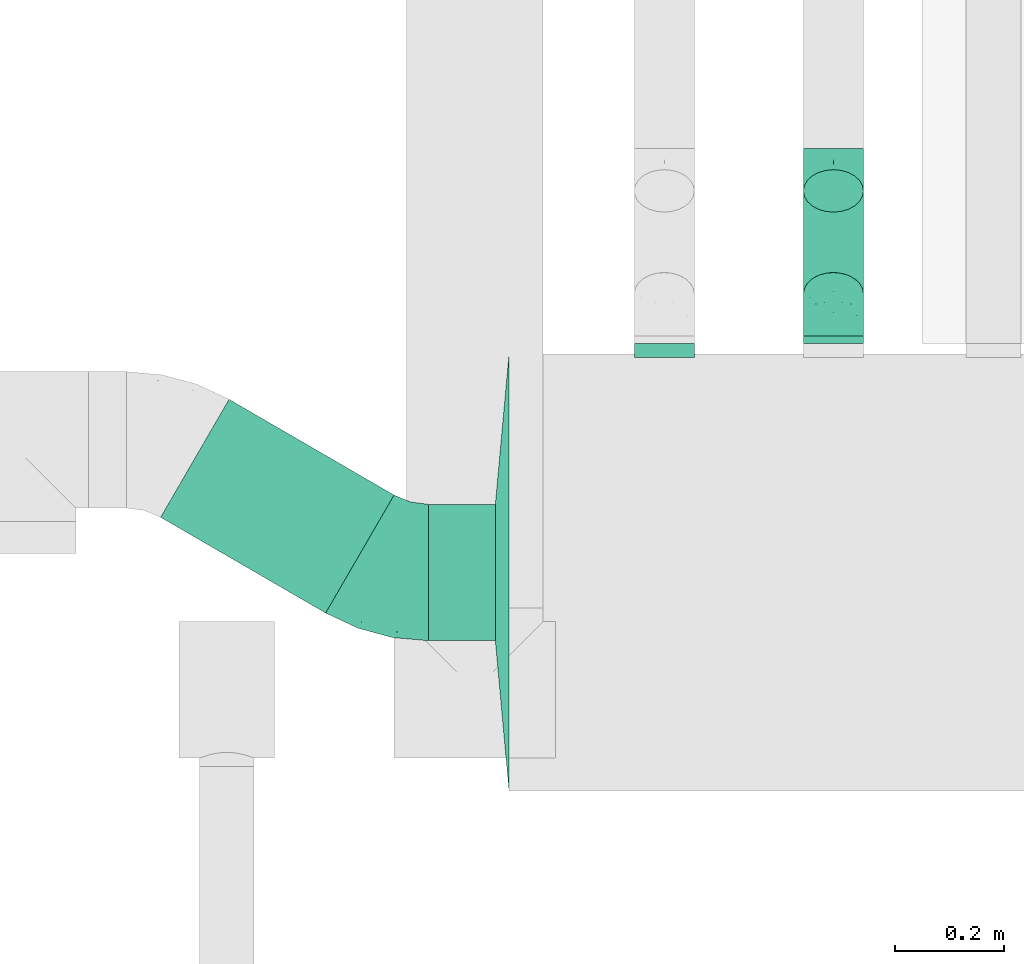
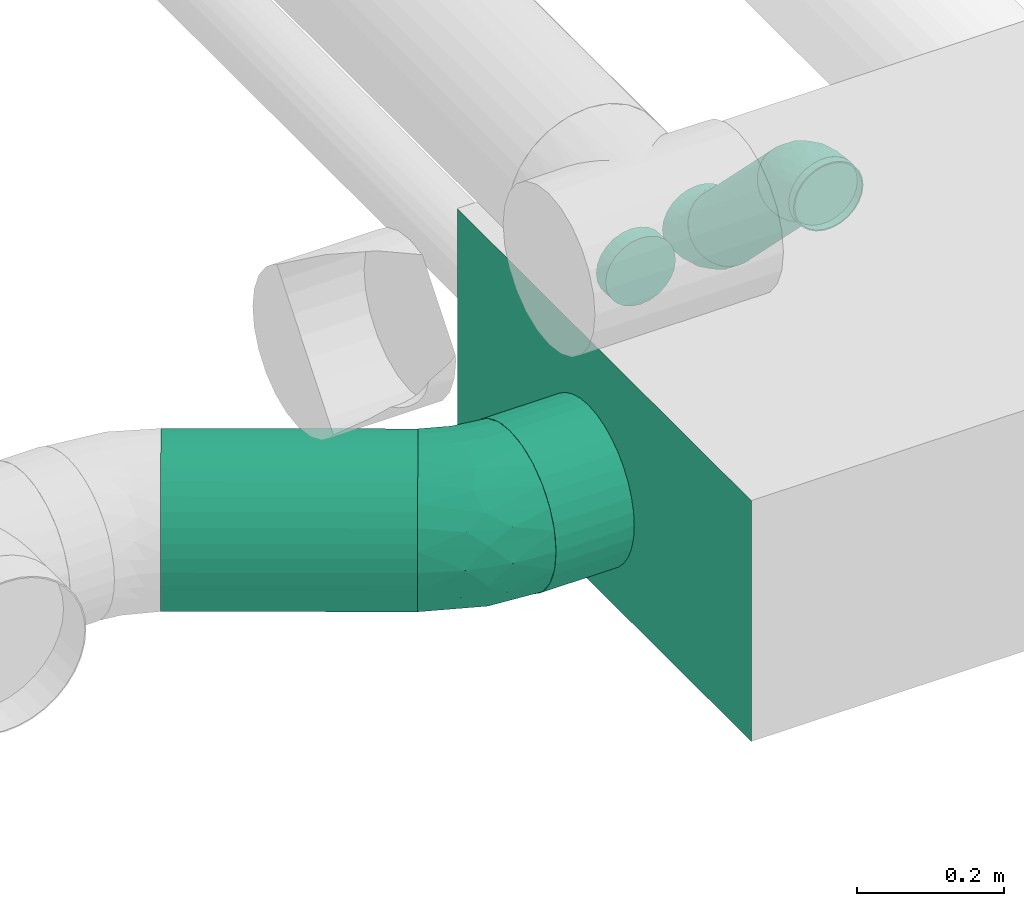
# One storey, part 19 of 91: 5 flow fittings, 4 flow segments.
"""IFC2X3 building model written with IfcOpenShell, lengths in millimetres."""

from ifc_helpers import new_model, entity, si_unit, converted_unit, derived_unit, direction, frame, origin_with_axes, origin_2d_with_axis, place, context, subcontext, project, spatial, hollow_circle, extrude, open_shell, surface_model, source, transform, mapped, material, layer, layer_set, layer_usage, type_object, element, save


model = new_model("IFC2X3")

# Units and contexts
model_context = context("Model", 3, precision=1e-05, world=origin_with_axes(), true_north=direction((0.0, 1.0)))
body_context = subcontext(model_context, "Body", "Model", "MODEL_VIEW")
ifc_project = project(units=[si_unit("AREAUNIT", "SQUARE_METRE"), si_unit("VOLUMEUNIT", "CUBIC_METRE", prefix="DECI"), si_unit("TIMEUNIT", "SECOND"), si_unit("THERMODYNAMICTEMPERATUREUNIT", "DEGREE_CELSIUS"), si_unit("PRESSUREUNIT", "PASCAL"), si_unit("MASSUNIT", "GRAM", prefix="KILO"), si_unit("LENGTHUNIT", "METRE", prefix="MILLI"), si_unit("POWERUNIT", "WATT"), si_unit("ELECTRICCURRENTUNIT", "AMPERE"), si_unit("ELECTRICVOLTAGEUNIT", "VOLT"), derived_unit("VOLUMETRICFLOWRATEUNIT", [(si_unit("VOLUMEUNIT", "CUBIC_METRE", prefix="DECI"), 1), (si_unit("TIMEUNIT", "SECOND"), -1)]), derived_unit("LINEARVELOCITYUNIT", [(si_unit("LENGTHUNIT", "METRE"), 1), (si_unit("TIMEUNIT", "SECOND"), -1)]), derived_unit("MASSDENSITYUNIT", [(si_unit("MASSUNIT", "GRAM", prefix="KILO"), 1), (si_unit("VOLUMEUNIT", "CUBIC_METRE"), -1)]), converted_unit("PLANEANGLEUNIT", "DEGREE", entity("IfcRatioMeasure", 0.01745), si_unit("PLANEANGLEUNIT", "RADIAN"), dimensions=[0, 0, 0, 0, 0, 0, 0])], contexts=[model_context])

# Site, building, storey
site_placement = place(None, origin_with_axes())
site = spatial("IfcSite", under=ifc_project, at=site_placement, CompositionType="ELEMENT")
building_placement = place(site_placement, origin_with_axes())
building = spatial("IfcBuilding", under=site, at=building_placement, Name="mc-building", CompositionType="ELEMENT")
storey_placement = place(building_placement, frame((0.0, 0.0, 8700.0), z_axis=(0.0, 0.0, 1.0), x_axis=(1.0, 0.0, 0.0)))
storey = spatial("IfcBuildingStorey", under=building, at=storey_placement, CompositionType="ELEMENT", Elevation=8700.0)

# Flow segment
ifc_material = material(Name="FZ1")
ifc_layer = layer(ifc_material, 0.0)
ifc_layer_set = layer_set([ifc_layer], Name="FZ1")
ifc_layer_usage = layer_usage(ifc_layer_set, "AXIS1", "POSITIVE", 0.0)
duct_segment_type_1 = type_object("IfcDuctSegmentType", PredefinedType="RIGIDSEGMENT")
shared_shape_1 = source(origin_with_axes(), body_context, "Body", "SweptSolid", [
    extrude(hollow_circle(Radius=55.0, WallThickness=2.0, at=origin_2d_with_axis()), frame((0.0, 0.0, 0.0), z_axis=(1.0, 0.0, 0.0), x_axis=(0.0, 1.0, 0.0)), (0.0, 0.0, 1.0), 266.7),
])
flow_segment_1_placement = place(storey_placement, frame((9076.57414, 8401.1274, 635.78175), z_axis=(0.0, 0.707107, 0.707107), x_axis=(0.0, 0.707107, -0.707107)))
element("IfcFlowSegment", 1, at=flow_segment_1_placement, inside=storey, type_object=duct_segment_type_1, material=ifc_layer_usage, context=body_context, shape_type="MappedRepresentation", body=[
    mapped(shared_shape_1, transform((0.0, 0.0, 0.0), scale=1.0)),
])

# Flow fittings
duct_fitting_type_1 = type_object("IfcDuctFittingType", Name="BU", PredefinedType="BEND")
shared_shape_2 = source(origin_with_axes(), body_context, "Body", "SurfaceModel", [
    surface_model("IfcShellBasedSurfaceModel", [(-45.56349, 0.0, -55.0), (-45.56349, -14.23505, -53.12592), (-45.56349, 14.23505, -53.12592), (-45.56349, 53.12592, 14.23505), (-45.56349, 27.5, -47.63139), (-45.56349, 38.89087, -38.89087), (-45.56349, 47.63139, -27.5), (-45.56349, -55.0, 0.0), (-45.56349, -53.12592, 14.23505), (-45.56349, -38.89087, -38.89087), (-45.56349, -27.5, -47.63139), (-45.56349, -53.12592, -14.23505), (-45.56349, -47.63139, -27.5), (-45.56349, 53.12592, -14.23505), (-45.56349, 47.63139, 27.5), (-45.56349, 38.89087, 38.89087), (-45.56349, -14.23505, 53.12592), (-45.56349, 27.5, 47.63139), (-45.56349, 14.23505, 53.12592), (-45.56349, -47.63139, 27.5), (-45.56349, -38.89087, 38.89087), (-45.56349, -27.5, 47.63139), (-45.56349, 0.0, 55.0), (-45.56349, 55.0, 0.0), (22.15256, 42.28395, -53.12592), (-6.67262, 71.10913, 0.0), (32.21826, 32.21826, -55.0), (12.77282, 51.66369, -47.63139), (-1.46223, 65.89874, -27.5), (4.71825, 59.71825, -38.89087), (59.71825, 4.71825, -38.89087), (69.78395, -5.34744, 14.23505), (51.66369, 12.77282, -47.63139), (42.28395, 22.15256, -53.12592), (65.89874, -1.46223, -27.5), (69.78395, -5.34744, -14.23505), (71.10913, -6.67262, 0.0), (-5.34744, 69.78395, -14.23505), (-5.34744, 69.78395, 14.23505), (-1.46223, 65.89874, 27.5), (4.71825, 59.71825, 38.89087), (32.21826, 32.21826, 55.0), (12.77282, 51.66369, 47.63139), (22.15256, 42.28395, 53.12592), (59.71825, 4.71825, 38.89087), (65.89874, -1.46223, 27.5), (42.28395, 22.15256, 53.12592), (51.66369, 12.77282, 47.63139), (-20.16649, 48.68621, 33.48188), (-26.97111, 35.77503, 43.63444), (-7.30443, 43.73336, 43.63444), (-17.0934, 3.74816, 55.0), (-18.00408, 15.44793, 53.78143), (-30.11707, 22.39897, 50.81337), (-7.49776, 55.63651, 33.48188), (-15.97018, 58.74288, 21.04759), (-31.18231, 52.58712, 21.04759), (-18.35174, 61.03934, 10.51509), (-28.67677, 56.60048, 10.47121), (-34.03924, 44.64267, 33.48188), (-11.52288, 27.81868, 50.81338), (1.19951, 23.16465, 53.81115), (-33.77926, 57.34403, 0.0), (5.4586, 37.12132, 50.81809), (-24.5159, 59.18663, 0.0), (-16.66281, 64.4339, 0.0), (9.43651, 14.73721, 55.0), (-6.22531, 44.36822, -43.63444), (5.4586, 37.12132, -50.81809), (-34.03924, 44.64267, -33.48188), (9.43651, 14.73721, -55.0), (-17.0934, 3.74816, -55.0), (1.19951, 23.16465, -53.81115), (-11.52288, 27.81868, -50.81338), (-30.11707, 22.39897, -50.81337), (-25.75914, 36.08917, -43.63444), (-30.24487, 52.83011, -21.04759), (-20.16649, 48.68621, -33.48188), (-7.49776, 55.63651, -33.48188), (-18.00408, 15.44793, -53.78143), (-28.68366, 56.62226, -10.35271), (-14.15883, 63.53074, -10.87592), (-15.13548, 59.23394, -21.04759), (3.19797, -7.72059, -52.16847), (3.1272, -18.04126, -47.9241), (13.63233, -32.91136, -32.06475), (45.23618, -22.99734, -20.4997), (16.67434, -40.25541, -15.9539), (-17.3935, -51.68264, -9.80849), (-2.85835, -49.37776, 0.0), (48.84421, -24.24609, -9.80849), (-16.38424, -42.76862, -30.85433), (-6.97383, -29.41689, -42.70541), (41.82739, -18.65658, -30.85433), (-15.72523, -48.24839, -20.4997), (29.28945, -13.63928, -42.80781), (26.81493, -3.56603, -49.15704), (36.93651, -32.89419, 0.0), (-15.72523, -48.24839, 20.4997), (-17.3935, -51.68264, 9.80849), (-16.38424, -42.76862, 30.85433), (16.67434, -40.25541, 15.9539), (3.19797, -7.72059, 52.16847), (10.54583, -14.96836, 47.9241), (13.63233, -32.91136, 32.06475), (45.23618, -22.99734, 20.4997), (41.82739, -18.65658, 30.85433), (-11.06635, -30.3552, 42.80781), (25.73213, -15.86964, 42.70541), (-16.43945, -21.48258, 49.15704), (48.84421, -24.24609, 9.80849)], [open_shell([[[0, 1, 2]], [[2, 3, 4]], [[5, 3, 6]], [[4, 3, 5]], [[2, 7, 8]], [[9, 7, 10]], [[1, 10, 7]], [[11, 7, 12]], [[9, 12, 7]], [[7, 2, 1]], [[13, 6, 3]], [[14, 3, 2]], [[15, 14, 2]], [[16, 17, 2]], [[2, 17, 15]], [[16, 18, 17]], [[19, 20, 2]], [[19, 2, 8]], [[20, 21, 2]], [[2, 21, 16]], [[16, 22, 18]], [[23, 13, 3]], [[24, 25, 26]], [[27, 25, 24]], [[28, 25, 29]], [[29, 25, 27]], [[30, 26, 31]], [[26, 30, 32]], [[32, 33, 26]], [[34, 31, 35]], [[31, 34, 30]], [[35, 31, 36]], [[37, 25, 28]], [[26, 38, 39]], [[26, 39, 40]], [[41, 40, 42]], [[26, 40, 41]], [[42, 43, 41]], [[26, 44, 45]], [[31, 26, 45]], [[46, 47, 26]], [[47, 44, 26]], [[46, 26, 41]], [[26, 25, 38]], [[48, 49, 50]], [[22, 51, 52]], [[17, 49, 15]], [[53, 17, 18]], [[49, 17, 53]], [[54, 50, 40]], [[48, 55, 56]], [[55, 57, 58]], [[59, 14, 15]], [[60, 53, 52]], [[50, 49, 60]], [[58, 3, 56]], [[52, 51, 61]], [[62, 23, 3]], [[63, 50, 60]], [[50, 42, 40]], [[3, 58, 62]], [[43, 61, 41]], [[62, 58, 64]], [[48, 59, 49]], [[14, 56, 3]], [[40, 39, 54]], [[57, 64, 58]], [[39, 38, 55]], [[63, 60, 61]], [[54, 55, 48]], [[65, 57, 38]], [[56, 14, 59]], [[38, 25, 65]], [[60, 52, 61]], [[49, 59, 15]], [[55, 58, 56]], [[56, 59, 48]], [[55, 54, 39]], [[50, 54, 48]], [[18, 22, 52]], [[49, 53, 60]], [[18, 52, 53]], [[61, 51, 66]], [[41, 61, 66]], [[63, 61, 43]], [[43, 42, 63]], [[50, 63, 42]], [[38, 57, 55]], [[64, 57, 65]], [[67, 27, 68]], [[69, 5, 6]], [[70, 71, 72]], [[73, 74, 75]], [[76, 77, 69]], [[29, 78, 28]], [[2, 79, 0]], [[13, 23, 62]], [[2, 74, 79]], [[5, 75, 4]], [[77, 78, 67]], [[13, 62, 80]], [[64, 80, 62]], [[81, 80, 64]], [[67, 73, 75]], [[82, 77, 76]], [[81, 64, 65]], [[76, 69, 6]], [[82, 76, 80]], [[24, 72, 68]], [[74, 2, 4]], [[27, 67, 29]], [[26, 70, 72]], [[69, 75, 5]], [[82, 28, 78]], [[72, 71, 79]], [[6, 13, 76]], [[77, 67, 75]], [[13, 80, 76]], [[82, 37, 28]], [[81, 25, 37]], [[82, 81, 37]], [[75, 69, 77]], [[67, 78, 29]], [[82, 78, 77]], [[75, 74, 4]], [[79, 74, 73]], [[79, 73, 72]], [[79, 71, 0]], [[68, 72, 73]], [[26, 72, 24]], [[67, 68, 73]], [[27, 24, 68]], [[80, 81, 82]], [[25, 81, 65]], [[1, 83, 84]], [[85, 86, 87]], [[0, 71, 1]], [[88, 87, 89]], [[90, 86, 35]], [[91, 92, 85]], [[11, 88, 7]], [[30, 34, 93]], [[11, 12, 94]], [[92, 91, 9]], [[85, 94, 91]], [[94, 85, 87]], [[95, 93, 85]], [[85, 92, 95]], [[83, 71, 70]], [[12, 9, 91]], [[70, 26, 33]], [[96, 84, 83]], [[1, 71, 83]], [[95, 96, 32]], [[95, 30, 93]], [[95, 32, 30]], [[97, 89, 87]], [[34, 86, 93]], [[36, 97, 90]], [[94, 88, 11]], [[34, 35, 86]], [[90, 87, 86]], [[93, 86, 85]], [[32, 96, 33]], [[84, 10, 1]], [[33, 83, 70]], [[94, 12, 91]], [[10, 92, 9]], [[87, 88, 94]], [[7, 88, 89]], [[36, 90, 35]], [[87, 90, 97]], [[84, 95, 92]], [[33, 96, 83]], [[95, 84, 96]], [[10, 84, 92]], [[8, 98, 19]], [[7, 89, 99]], [[19, 98, 100]], [[101, 98, 99]], [[46, 102, 103]], [[104, 105, 106]], [[100, 98, 104]], [[107, 104, 108]], [[16, 51, 22]], [[51, 16, 102]], [[107, 20, 100]], [[107, 109, 21]], [[21, 20, 107]], [[103, 47, 46]], [[101, 89, 97]], [[105, 110, 31]], [[44, 47, 108]], [[105, 104, 101]], [[107, 100, 104]], [[31, 110, 36]], [[109, 16, 21]], [[108, 106, 44]], [[105, 45, 106]], [[41, 66, 46]], [[102, 66, 51]], [[46, 66, 102]], [[104, 98, 101]], [[99, 98, 8]], [[106, 108, 104]], [[110, 101, 97]], [[45, 44, 106]], [[105, 31, 45]], [[20, 19, 100]], [[109, 103, 102]], [[101, 110, 105]], [[36, 110, 97]], [[7, 99, 8]], [[101, 99, 89]], [[103, 107, 108]], [[16, 109, 102]], [[107, 103, 109]], [[47, 103, 108]]])]),
])
for number, where, z_axis, x_axis, name in (
    (2, (9076.57414, 8368.90914, 668.0), (1.0, 0.0, 0.0), (0.0, -0.707107, 0.707107), "BU"),
    (3, (9076.57414, 8621.90914, 415.0), (-1.0, 0.0, 0.0), (0.0, -1.0, 0.0), "BU"),
):
    element("IfcFlowFitting", number, at=place(storey_placement, frame(where, z_axis=z_axis, x_axis=x_axis)), inside=storey, type_object=duct_fitting_type_1, Name=name, context=body_context, shape_type="MappedRepresentation", body=[
        mapped(shared_shape_2, transform((0.0, 0.0, 0.0), scale=1.0)),
    ])
duct_fitting_type_2 = type_object("IfcDuctFittingType", Name="CC", PredefinedType="CONNECTOR")
shared_shape_3 = source(origin_with_axes(), body_context, "Body", "SurfaceModel", [
    surface_model("IfcShellBasedSurfaceModel", [(-6.096, -55.0, 0.0), (-6.096, 0.0, -55.0), (-6.096, -14.23505, -53.12592), (-6.096, -27.5, -47.63139), (-6.096, -38.89087, -38.89087), (-6.096, -47.63139, -27.5), (-6.096, 38.89087, -38.89087), (-6.096, 53.12592, 14.23505), (-6.096, 27.5, -47.63139), (-6.096, 14.23505, -53.12592), (-6.096, 47.63139, -27.5), (-6.096, 53.12592, -14.23505), (-6.096, 55.0, 0.0), (-6.096, -53.12592, -14.23505), (-6.096, -53.12592, 14.23505), (-6.096, -47.63139, 27.5), (-6.096, -38.89087, 38.89087), (-6.096, 0.0, 55.0), (-6.096, -27.5, 47.63139), (-6.096, -14.23505, 53.12592), (-6.096, 38.89087, 38.89087), (-6.096, 47.63139, 27.5), (-6.096, 14.23505, 53.12592), (-6.096, 27.5, 47.63139), (0.0, -14.23505, 53.12592), (0.0, 0.0, 55.0), (0.0, -27.5, 47.63139), (0.0, -38.89087, 38.89087), (0.0, -53.12592, 14.23505), (0.0, -47.63139, 27.5), (0.0, -55.0, 0.0), (0.0, -53.12592, -14.23505), (0.0, -47.63139, -27.5), (0.0, -38.89087, -38.89087), (0.0, -14.23505, -53.12592), (0.0, -27.5, -47.63139), (0.0, 0.0, -55.0), (0.0, 14.23505, -53.12592), (0.0, 27.5, -47.63139), (0.0, 38.89087, -38.89087), (0.0, 53.12592, -14.23505), (0.0, 47.63139, -27.5), (0.0, 55.0, 0.0), (0.0, 53.12592, 14.23505), (0.0, 47.63139, 27.5), (0.0, 38.89087, 38.89087), (0.0, 14.23505, 53.12592), (0.0, 27.5, 47.63139), (20.0, 0.0, -55.0), (20.0, 14.23505, -53.12592), (20.0, -14.23505, -53.12592), (20.0, -53.12592, 14.23505), (20.0, -27.5, -47.63139), (20.0, -47.63139, -27.5), (20.0, -38.89087, -38.89087), (20.0, 55.0, 0.0), (20.0, 53.12592, 14.23505), (20.0, 38.89087, -38.89087), (20.0, 27.5, -47.63139), (20.0, 53.12592, -14.23505), (20.0, 47.63139, -27.5), (20.0, -53.12592, -14.23505), (20.0, -47.63139, 27.5), (20.0, -38.89087, 38.89087), (20.0, 14.23505, 53.12592), (20.0, -27.5, 47.63139), (20.0, -14.23505, 53.12592), (20.0, 47.63139, 27.5), (20.0, 38.89087, 38.89087), (20.0, 27.5, 47.63139), (20.0, 0.0, 55.0), (20.0, -55.0, 0.0)], [open_shell([[[0, 1, 2]], [[3, 0, 2]], [[0, 4, 5]], [[4, 0, 3]], [[6, 1, 7]], [[1, 6, 8]], [[8, 9, 1]], [[6, 7, 10]], [[10, 7, 11]], [[12, 11, 7]], [[13, 0, 5]], [[14, 15, 1]], [[1, 15, 16]], [[17, 16, 18]], [[17, 1, 16]], [[19, 17, 18]], [[20, 21, 1]], [[7, 1, 21]], [[22, 23, 1]], [[23, 20, 1]], [[22, 1, 17]], [[0, 14, 1]], [[24, 25, 17]], [[26, 24, 19]], [[19, 24, 17]], [[16, 27, 18]], [[26, 19, 18]], [[26, 18, 27]], [[28, 29, 15]], [[30, 28, 14]], [[15, 29, 16]], [[28, 15, 14]], [[30, 14, 0]], [[27, 16, 29]], [[31, 30, 0]], [[32, 31, 13]], [[13, 31, 0]], [[4, 33, 5]], [[32, 13, 5]], [[32, 5, 33]], [[34, 35, 3]], [[36, 34, 2]], [[3, 35, 4]], [[34, 3, 2]], [[36, 2, 1]], [[33, 4, 35]], [[37, 36, 1]], [[38, 37, 9]], [[9, 37, 1]], [[6, 39, 8]], [[38, 9, 8]], [[38, 8, 39]], [[40, 41, 10]], [[42, 40, 11]], [[10, 41, 6]], [[40, 10, 11]], [[42, 11, 12]], [[39, 6, 41]], [[43, 42, 12]], [[44, 43, 7]], [[7, 43, 12]], [[20, 45, 21]], [[44, 7, 21]], [[44, 21, 45]], [[46, 47, 23]], [[25, 46, 22]], [[23, 47, 20]], [[46, 23, 22]], [[25, 22, 17]], [[45, 20, 47]], [[48, 49, 50]], [[50, 51, 52]], [[53, 54, 51]], [[52, 51, 54]], [[50, 55, 56]], [[57, 55, 58]], [[49, 58, 55]], [[59, 55, 60]], [[57, 60, 55]], [[55, 50, 49]], [[53, 51, 61]], [[50, 62, 51]], [[63, 62, 50]], [[64, 65, 50]], [[65, 63, 50]], [[64, 66, 65]], [[50, 67, 68]], [[67, 50, 56]], [[68, 69, 50]], [[50, 69, 64]], [[64, 70, 66]], [[71, 61, 51]], [[66, 70, 25]], [[65, 66, 24]], [[24, 66, 25]], [[27, 63, 26]], [[65, 24, 26]], [[65, 26, 63]], [[51, 62, 29]], [[71, 51, 28]], [[29, 62, 27]], [[51, 29, 28]], [[71, 28, 30]], [[63, 27, 62]], [[61, 71, 30]], [[53, 61, 31]], [[31, 61, 30]], [[33, 54, 32]], [[53, 31, 32]], [[53, 32, 54]], [[50, 52, 35]], [[48, 50, 34]], [[35, 52, 33]], [[50, 35, 34]], [[48, 34, 36]], [[54, 33, 52]], [[49, 48, 36]], [[58, 49, 37]], [[37, 49, 36]], [[39, 57, 38]], [[58, 37, 38]], [[58, 38, 57]], [[59, 60, 41]], [[55, 59, 40]], [[41, 60, 39]], [[59, 41, 40]], [[55, 40, 42]], [[57, 39, 60]], [[56, 55, 42]], [[67, 56, 43]], [[43, 56, 42]], [[45, 68, 44]], [[67, 43, 44]], [[67, 44, 68]], [[64, 69, 47]], [[70, 64, 46]], [[47, 69, 45]], [[64, 47, 46]], [[70, 46, 25]], [[68, 45, 69]], [[50, 63, 62]], [[50, 64, 65]], [[50, 56, 67]], [[50, 68, 69]], [[64, 50, 69]]])]),
])
flow_fitting_1_placement = place(storey_placement, frame((8766.57414, 8290.34565, 668.0), z_axis=(0.0, 0.0, -1.0), x_axis=(0.0, 1.0, 0.0)))
element("IfcFlowFitting", 4, at=flow_fitting_1_placement, inside=storey, type_object=duct_fitting_type_2, Name="CC", context=body_context, shape_type="MappedRepresentation", body=[
    mapped(shared_shape_3, transform((0.0, 0.0, 0.0), scale=1.0)),
])

# Flow segment
shared_shape_4 = source(origin_with_axes(), body_context, "Body", "SweptSolid", [
    extrude(hollow_circle(Radius=55.0, WallThickness=2.0, at=origin_2d_with_axis()), frame((0.0, 0.0, 0.0), z_axis=(1.0, 0.0, 0.0), x_axis=(0.0, 1.0, 0.0)), (0.0, 0.0, 1.0), 13.0),
])
flow_segment_2_placement = place(storey_placement, frame((9076.57414, 8310.34565, 668.0), z_axis=(0.0, 0.0, 1.0), x_axis=(0.0, 1.0, 0.0)))
element("IfcFlowSegment", 5, at=flow_segment_2_placement, inside=storey, type_object=duct_segment_type_1, material=ifc_layer_usage, context=body_context, shape_type="MappedRepresentation", body=[
    mapped(shared_shape_4, transform((0.0, 0.0, 0.0), scale=1.0, scale2=1.0, scale3=1.0, uniform=False)),
])

# Flow fitting
duct_fitting_type_3 = type_object("IfcDuctFittingType", Name="RC", PredefinedType="TRANSITION")
shared_shape_5 = source(origin_with_axes(), body_context, "Body", "SurfaceModel", [
    surface_model("IfcShellBasedSurfaceModel", [(25.0, -38.62713, 118.88206), (25.0, -38.62713, -118.88206), (25.0, 0.0, 125.0), (25.0, -73.47315, 101.12712), (25.0, -73.47315, -101.12712), (25.0, -101.12712, 73.47315), (25.0, -101.12712, -73.47315), (25.0, -118.88206, 38.62713), (25.0, 38.62713, 118.88206), (25.0, 0.0, -125.0), (25.0, 73.47315, 101.12712), (25.0, 101.12712, -73.47315), (25.0, 101.12712, 73.47315), (25.0, 118.88206, 38.62713), (25.0, 73.47315, -101.12712), (25.0, -125.0, 0.0), (25.0, -118.88206, -38.62713), (25.0, 38.62713, -118.88206), (25.0, 125.0, 0.0), (25.0, 118.88206, -38.62713), (0.0, -400.0, 200.0), (0.0, 400.0, 200.0), (0.0, -400.0, -200.0), (0.0, 400.0, -200.0), (10.19698, -248.17626, 168.13469), (6.79799, -291.23219, 179.60604), (13.14003, -236.2166, 141.3368), (11.75909, -238.062, 158.55882), (17.96512, -188.25993, 104.63046), (11.75909, -264.48613, 132.13469), (18.13043, -194.35287, 87.93753), (18.13043, -142.89409, 139.3963), (18.35922, -196.54765, 69.65811), (13.59598, -182.46439, 159.21207), (18.35922, -122.78432, 143.42142), (17.96512, -160.90946, 131.98092), (6.79799, -325.22212, 145.61608), (10.19698, -286.55884, 129.75214), (13.59597, -250.44429, 91.23221), (10.19698, -286.55882, -129.75212), (6.79799, -325.22212, -145.61609), (13.14003, -236.2166, -141.3368), (11.75909, -264.48613, -132.13469), (17.96512, -160.90946, -131.98092), (11.75909, -238.062, -158.55882), (18.13043, -142.8941, -139.3963), (18.13043, -194.35285, -87.93753), (18.35922, -122.78434, -143.42142), (13.59598, -250.44427, -91.23219), (18.35922, -196.54765, -69.6581), (17.96512, -188.25993, -104.63046), (6.79799, -291.23217, -179.60602), (10.19698, -248.17628, -168.13469), (13.59597, -182.46443, -159.21208), (10.19698, 248.17626, -168.13469), (6.79799, 291.23219, -179.60604), (13.14003, 236.2166, -141.3368), (11.75909, 238.062, -158.55882), (17.96512, 188.25993, -104.63046), (11.75909, 264.48613, -132.13469), (18.13043, 194.35287, -87.93753), (18.13043, 142.89409, -139.3963), (18.35922, 196.54765, -69.65811), (13.59598, 182.46439, -159.21207), (18.35922, 122.78432, -143.42142), (17.96512, 160.90946, -131.98092), (6.79799, 325.22212, -145.61608), (10.19698, 286.55884, -129.75214), (13.59597, 250.44429, -91.23221), (10.19698, 286.55882, 129.75212), (6.79799, 325.22212, 145.61609), (13.14003, 236.2166, 141.3368), (11.75909, 264.48613, 132.13469), (17.96512, 160.90946, 131.98092), (11.75909, 238.062, 158.55882), (18.13043, 142.8941, 139.3963), (18.13043, 194.35285, 87.93753), (18.35922, 122.78434, 143.42142), (13.59598, 250.44427, 91.23219), (18.35922, 196.54765, 69.6581), (17.96512, 188.25993, 104.63046), (6.79799, 291.23217, 179.60602), (10.19698, 248.17628, 168.13469), (13.59597, 182.46443, 159.21208)], [open_shell([[[0, 1, 2]], [[3, 4, 0]], [[5, 6, 3]], [[6, 5, 7]], [[8, 2, 9]], [[10, 11, 12]], [[13, 12, 11]], [[14, 10, 8]], [[7, 15, 16]], [[4, 3, 6]], [[1, 9, 2]], [[0, 4, 1]], [[17, 8, 9]], [[18, 13, 19]], [[13, 11, 19]], [[11, 10, 14]], [[17, 14, 8]], [[16, 6, 7]], [[20, 21, 22]], [[23, 22, 21]], [[20, 24, 25]], [[26, 27, 20]], [[28, 29, 30]], [[31, 24, 27]], [[15, 7, 32]], [[25, 24, 33]], [[5, 3, 26]], [[34, 2, 33]], [[2, 34, 0]], [[31, 35, 3]], [[36, 37, 20]], [[32, 37, 38]], [[34, 31, 0]], [[37, 32, 30]], [[3, 0, 31]], [[30, 5, 28]], [[38, 37, 36]], [[29, 26, 20]], [[20, 27, 24]], [[37, 29, 20]], [[24, 34, 33]], [[15, 32, 38]], [[30, 32, 7]], [[24, 31, 34]], [[31, 27, 35]], [[27, 26, 35]], [[26, 3, 35]], [[5, 30, 7]], [[37, 30, 29]], [[5, 26, 28]], [[26, 29, 28]], [[20, 22, 15]], [[22, 39, 40]], [[41, 42, 22]], [[43, 44, 45]], [[46, 39, 42]], [[9, 1, 47]], [[40, 39, 48]], [[4, 6, 41]], [[49, 15, 48]], [[15, 49, 16]], [[46, 50, 6]], [[51, 52, 22]], [[47, 52, 53]], [[49, 46, 16]], [[52, 47, 45]], [[6, 16, 46]], [[45, 4, 43]], [[53, 52, 51]], [[44, 41, 22]], [[22, 42, 39]], [[52, 44, 22]], [[39, 49, 48]], [[9, 47, 53]], [[45, 47, 1]], [[39, 46, 49]], [[46, 42, 50]], [[42, 41, 50]], [[41, 6, 50]], [[4, 45, 1]], [[52, 45, 44]], [[4, 41, 43]], [[41, 44, 43]], [[22, 23, 9]], [[23, 54, 55]], [[56, 57, 23]], [[58, 59, 60]], [[61, 54, 57]], [[18, 19, 62]], [[55, 54, 63]], [[11, 14, 56]], [[64, 9, 63]], [[9, 64, 17]], [[61, 65, 14]], [[66, 67, 23]], [[62, 67, 68]], [[64, 61, 17]], [[67, 62, 60]], [[14, 17, 61]], [[60, 11, 58]], [[68, 67, 66]], [[59, 56, 23]], [[23, 57, 54]], [[67, 59, 23]], [[54, 64, 63]], [[18, 62, 68]], [[60, 62, 19]], [[54, 61, 64]], [[61, 57, 65]], [[57, 56, 65]], [[56, 14, 65]], [[11, 60, 19]], [[67, 60, 59]], [[11, 56, 58]], [[56, 59, 58]], [[23, 21, 18]], [[21, 69, 70]], [[71, 72, 21]], [[73, 74, 75]], [[76, 69, 72]], [[2, 8, 77]], [[70, 69, 78]], [[10, 12, 71]], [[79, 18, 78]], [[18, 79, 13]], [[76, 80, 12]], [[81, 82, 21]], [[77, 82, 83]], [[79, 76, 13]], [[82, 77, 75]], [[12, 13, 76]], [[75, 10, 73]], [[83, 82, 81]], [[74, 71, 21]], [[21, 72, 69]], [[82, 74, 21]], [[69, 79, 78]], [[2, 77, 83]], [[75, 77, 8]], [[69, 76, 79]], [[76, 72, 80]], [[72, 71, 80]], [[71, 12, 80]], [[10, 75, 8]], [[82, 75, 74]], [[10, 71, 73]], [[71, 74, 73]], [[21, 20, 2]]])]),
])
flow_fitting_2_placement = place(storey_placement, frame((8482.02245, 7890.34565, 668.0), z_axis=(0.0, 0.0, 1.0), x_axis=(-1.0, 0.0, 0.0)))
element("IfcFlowFitting", 6, at=flow_fitting_2_placement, inside=storey, type_object=duct_fitting_type_3, Name="RC", context=body_context, shape_type="MappedRepresentation", body=[
    mapped(shared_shape_5, transform((0.0, 0.0, 0.0), scale=1.0)),
])

# Flow segments
duct_segment_type_2 = type_object("IfcDuctSegmentType", Name="Safe", PredefinedType="RIGIDSEGMENT")
shared_shape_6 = source(origin_with_axes(), body_context, "Body", "SweptSolid", [
    extrude(hollow_circle(Radius=125.0, WallThickness=2.0, at=origin_2d_with_axis()), frame((0.0, 0.0, 0.0), z_axis=(1.0, 0.0, 0.0), x_axis=(0.0, 1.0, 0.0)), (0.0, 0.0, 1.0), 122.9),
])
flow_segment_3_placement = place(storey_placement, frame((8457.02245, 7890.34565, 668.0), z_axis=(0.0, 0.0, 1.0), x_axis=(-1.0, 0.0, 0.0)))
element("IfcFlowSegment", 7, at=flow_segment_3_placement, inside=storey, type_object=duct_segment_type_2, material=ifc_layer_usage, Name="Safe", context=body_context, shape_type="MappedRepresentation", body=[
    mapped(shared_shape_6, transform((0.0, 0.0, 0.0), scale=1.0)),
])
shared_shape_7 = source(origin_with_axes(), body_context, "Body", "SweptSolid", [
    extrude(hollow_circle(Radius=125.0, WallThickness=2.0, at=origin_2d_with_axis()), frame((0.0, 0.0, 0.0), z_axis=(1.0, 0.0, 0.0), x_axis=(0.0, 1.0, 0.0)), (0.0, 0.0, 1.0), 349.7),
])
flow_segment_4_placement = place(storey_placement, frame((8208.66275, 7924.11962, 668.0), z_axis=(0.0, 0.0, 1.0), x_axis=(-0.864904, 0.501937, 0.0)))
element("IfcFlowSegment", 8, at=flow_segment_4_placement, inside=storey, type_object=duct_segment_type_2, material=ifc_layer_usage, Name="Safe", context=body_context, shape_type="MappedRepresentation", body=[
    mapped(shared_shape_7, transform((0.0, 0.0, 0.0), scale=1.0)),
])

# Flow fitting
shared_shape_8 = source(origin_with_axes(), body_context, "Body", "SurfaceModel", [
    surface_model("IfcShellBasedSurfaceModel", [(-67.28726, 0.0, -125.0), (-67.28726, -32.35238, -120.74073), (-67.28726, 32.35238, -120.74073), (-67.28726, 120.74073, 32.35238), (-67.28726, 62.5, -108.25318), (-67.28726, 108.25318, -62.5), (-67.28726, 88.38835, -88.38835), (-67.28726, -125.0, 0.0), (-67.28726, -120.74073, 32.35238), (-67.28726, -88.38835, -88.38835), (-67.28726, -62.5, -108.25318), (-67.28726, -120.74073, -32.35238), (-67.28726, -108.25318, -62.5), (-67.28726, 120.74073, -32.35238), (-67.28726, 108.25318, 62.5), (-67.28726, 88.38835, 88.38835), (-67.28726, 32.35238, 120.74073), (-67.28726, 62.5, 108.25318), (-67.28726, 0.0, 125.0), (-67.28726, -108.25318, 62.5), (-67.28726, -88.38835, 88.38835), (-67.28726, -32.35238, 120.74073), (-67.28726, -62.5, 108.25318), (-67.28726, 125.0, 0.0), (41.95816, 61.75568, -120.74073), (-4.54512, 141.88699, 0.0), (58.19702, 33.77397, -125.0), (26.82595, 87.83048, -108.25318), (13.83163, 110.22142, -88.38835), (3.86074, 127.40259, -62.5), (102.56242, -42.67347, -88.38835), (118.80128, -70.65518, 32.35238), (89.5681, -20.28253, -108.25318), (74.43589, 5.79227, -120.74073), (112.53331, -59.85465, -62.5), (118.80128, -70.65518, -32.35238), (120.93917, -74.33904, 0.0), (-2.40723, 138.20313, -32.35238), (-2.40723, 138.20313, 32.35238), (3.86074, 127.40259, 62.5), (13.83163, 110.22142, 88.38835), (26.82595, 87.83048, 108.25318), (41.95816, 61.75568, 120.74073), (102.56242, -42.67347, 88.38835), (112.53331, -59.85465, 62.5), (89.5681, -20.28253, 108.25318), (74.43589, 5.79227, 120.74073), (58.19702, 33.77397, 125.0), (2.7391, 65.72477, 113.2695), (-31.8085, 59.10588, 111.83577), (-11.02899, 40.97728, 120.41659), (-23.69154, 3.83052, 125.0), (-22.08941, 82.07131, 99.16917), (-32.32681, 120.10748, 47.83543), (-35.40677, 102.5769, 76.09517), (-47.13657, 124.91618, 20.52456), (18.56823, 15.20469, 125.0), (-24.79608, 129.89284, 24.38629), (-34.79977, 129.29555, 0.0), (-44.73771, 124.83011, -23.26878), (-28.08634, 104.35239, -76.09517), (-13.76184, 84.53725, -99.16917), (-38.85537, 118.52404, -47.83543), (-11.02899, 40.97728, -120.41659), (-0.36968, 66.57614, -112.37151), (-23.69154, 3.83052, -125.0), (-34.58941, 56.24486, -112.96988), (-22.40853, 131.40134, -21.17123), (18.56823, 15.20469, -125.0), (10.72915, -39.86321, -114.48624), (23.74355, -88.21712, -74.66097), (-8.41227, -108.78488, -52.19026), (4.18859, -15.56234, -122.47183), (54.47512, -91.21914, -54.91056), (29.00263, -107.75676, -33.27987), (27.92352, -63.50076, -97.96461), (-1.89368, -119.25422, 0.0), (61.49597, -102.19296, 0.0), (-1.32948, -106.2389, 54.91056), (23.74355, -88.21712, 74.66097), (29.00263, -107.75676, 33.27987), (10.72915, -39.86321, 114.48624), (4.18859, -15.56234, 122.47183), (7.72222, -68.93793, 97.96461), (61.87897, -89.86605, 52.19026)], [open_shell([[[0, 1, 2]], [[2, 3, 4]], [[5, 6, 3]], [[3, 6, 4]], [[2, 7, 8]], [[9, 7, 10]], [[2, 1, 10]], [[11, 7, 12]], [[9, 12, 7]], [[10, 7, 2]], [[13, 5, 3]], [[14, 3, 2]], [[14, 2, 15]], [[2, 16, 17]], [[17, 15, 2]], [[16, 2, 18]], [[19, 20, 2]], [[2, 8, 19]], [[21, 18, 22]], [[20, 22, 18]], [[18, 2, 20]], [[23, 13, 3]], [[24, 25, 26]], [[27, 25, 24]], [[25, 28, 29]], [[27, 28, 25]], [[30, 26, 31]], [[26, 30, 32]], [[32, 33, 26]], [[30, 31, 34]], [[35, 34, 31]], [[35, 31, 36]], [[37, 25, 29]], [[38, 39, 26]], [[39, 40, 26]], [[41, 42, 26]], [[26, 40, 41]], [[43, 26, 42]], [[26, 44, 31]], [[43, 44, 26]], [[42, 45, 43]], [[42, 46, 45]], [[47, 46, 42]], [[38, 26, 25]], [[48, 49, 50]], [[16, 18, 51]], [[15, 17, 52]], [[49, 16, 50]], [[16, 49, 17]], [[39, 38, 53]], [[54, 14, 15]], [[15, 52, 54]], [[53, 14, 54]], [[49, 52, 17]], [[41, 48, 42]], [[55, 23, 3]], [[51, 56, 50]], [[55, 57, 58]], [[54, 39, 53]], [[51, 50, 16]], [[52, 48, 41]], [[47, 42, 56]], [[25, 57, 38]], [[57, 53, 38]], [[53, 3, 14]], [[39, 54, 40]], [[25, 58, 57]], [[52, 49, 48]], [[40, 54, 52]], [[57, 55, 53]], [[40, 52, 41]], [[42, 48, 50]], [[53, 55, 3]], [[42, 50, 56]], [[23, 55, 58]], [[23, 59, 13]], [[60, 6, 5]], [[28, 60, 29]], [[61, 6, 60]], [[5, 62, 60]], [[24, 63, 64]], [[0, 2, 65]], [[24, 64, 27]], [[63, 65, 2]], [[61, 64, 66]], [[29, 62, 37]], [[64, 61, 27]], [[23, 58, 59]], [[61, 28, 27]], [[29, 60, 62]], [[6, 61, 4]], [[37, 67, 25]], [[62, 67, 37]], [[62, 5, 13]], [[68, 63, 24]], [[61, 60, 28]], [[24, 26, 68]], [[59, 62, 13]], [[25, 67, 58]], [[65, 63, 68]], [[66, 2, 4]], [[67, 59, 58]], [[2, 66, 63]], [[59, 67, 62]], [[61, 66, 4]], [[66, 64, 63]], [[69, 10, 1]], [[70, 71, 12]], [[65, 72, 0]], [[71, 73, 74]], [[11, 71, 74]], [[75, 9, 10]], [[7, 11, 76]], [[77, 74, 35]], [[9, 70, 12]], [[74, 76, 11]], [[70, 73, 71]], [[72, 65, 68]], [[26, 33, 72]], [[9, 75, 70]], [[69, 33, 32]], [[1, 72, 69]], [[30, 70, 75]], [[69, 32, 75]], [[74, 73, 35]], [[30, 34, 70]], [[35, 36, 77]], [[0, 72, 1]], [[73, 70, 34]], [[74, 77, 76]], [[32, 30, 75]], [[12, 71, 11]], [[72, 68, 26]], [[69, 72, 33]], [[35, 73, 34]], [[10, 69, 75]], [[78, 79, 19]], [[8, 7, 76]], [[20, 19, 79]], [[80, 8, 76]], [[8, 80, 78]], [[43, 79, 44]], [[46, 81, 45]], [[81, 21, 22]], [[82, 18, 21]], [[21, 81, 82]], [[20, 79, 83]], [[46, 82, 81]], [[83, 81, 22]], [[82, 51, 18]], [[77, 80, 76]], [[22, 20, 83]], [[45, 81, 83]], [[78, 84, 79]], [[36, 31, 77]], [[84, 31, 44]], [[8, 78, 19]], [[56, 82, 47]], [[82, 56, 51]], [[46, 47, 82]], [[79, 84, 44]], [[31, 84, 80]], [[45, 83, 43]], [[84, 78, 80]], [[31, 80, 77]], [[43, 83, 79]]])]),
])
flow_fitting_3_placement = place(storey_placement, frame((8266.85978, 7890.34565, 668.0), z_axis=(0.0, 0.0, 1.0), x_axis=(0.864904, -0.501937, 0.0)))
element("IfcFlowFitting", 9, at=flow_fitting_3_placement, inside=storey, type_object=duct_fitting_type_1, Name="BU", context=body_context, shape_type="MappedRepresentation", body=[
    mapped(shared_shape_8, transform((0.0, 0.0, 0.0), scale=1.0)),
])

save(model, "model.ifc")
